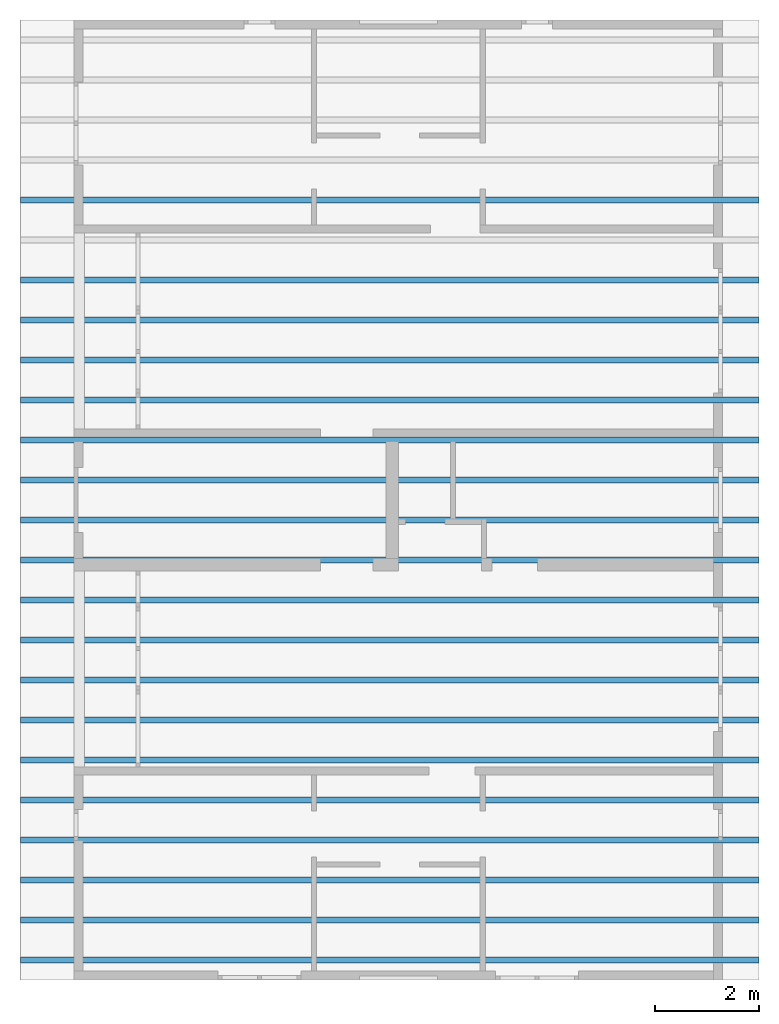
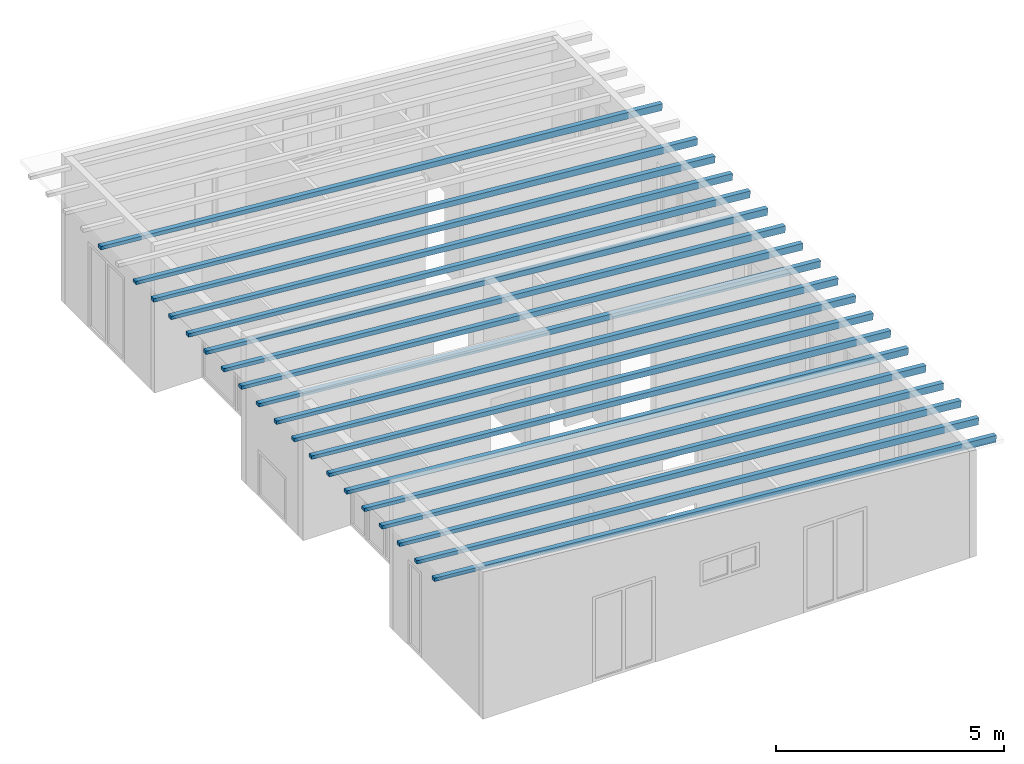
# One storey, part 3 of 13: 19 beams.
"""IFC2X3 building model written with IfcOpenShell, lengths in millimetres."""

import ifcopenshell
import ifcopenshell.guid

model = None  # the IFC model being written
_history = None  # IfcOwnerHistory: only IFC2X3 demands one
_inside = {}  # id of a spatial element -> (the spatial element, [elements in it])
_under = {}  # id of a project, library or spatial element -> (it, [spatial elements below it])
_declared = {}  # id of a project -> (the project, [libraries it declares])
_typed = {}  # id of a type object -> (the type object, [elements of that type])
_made_of = {}  # id of a material, layer set ... -> (it, [elements and type objects made of it])


def new_model(schema):
    """Start an empty IFC model of exactly this schema.

    Asked for "IFC4X3", IfcOpenShell would pick the latest addendum, in which some entities
    have other attributes; the version numbers below select the first issue.
    IFC2X3 requires an IfcOwnerHistory on every rooted entity: one is made here for all.
    """
    global model, _history
    if schema == "IFC4X3":
        model = ifcopenshell.file(schema_version=(4, 3, 0, 0))
    else:
        model = ifcopenshell.file(schema=schema)
    _inside.clear()
    _under.clear()
    _declared.clear()
    _typed.clear()
    _made_of.clear()
    _history = None
    if model.schema == "IFC2X3":
        org = make("IfcOrganization", Name="unknown")
        user = make(
            "IfcPersonAndOrganization",
            ThePerson=make("IfcPerson", FamilyName="unknown"),
            TheOrganization=org,
        )
        app = make(
            "IfcApplication",
            ApplicationDeveloper=org,
            Version="unknown",
            ApplicationFullName="unknown",
            ApplicationIdentifier="unknown",
        )
        _history = make(
            "IfcOwnerHistory",
            OwningUser=user,
            OwningApplication=app,
            ChangeAction="ADDED",
            CreationDate=0,
        )
    return model


def make(cls, **values):
    """One entity of the class cls with the attributes given. An attribute that is None is left unset."""
    return model.create_entity(
        cls, **{name: value for name, value in values.items() if value is not None}
    )


def entity(cls, *values):
    """Any entity or typed value of the class cls, its attributes in the order of the schema. None: left unset."""
    e = model.create_entity(cls)
    for i, value in enumerate(values):
        if value is not None:
            e[i] = value
    return e


def rooted(cls, **values):
    """An entity with a GlobalId (a new one), such as an element, a storey or a relation."""
    return make(cls, GlobalId=ifcopenshell.guid.new(), OwnerHistory=_history, **values)


def si_unit(unit_type, name, prefix=None):
    """IfcSIUnit, for example si_unit("LENGTHUNIT", "METRE", prefix="MILLI")."""
    return make("IfcSIUnit", UnitType=unit_type, Prefix=prefix, Name=name)


def converted_unit(unit_type, name, factor, base, dimensions=None, offset=None):
    """IfcConversionBasedUnit, such as the inch: factor (a typed value) times the base unit."""
    return make(
        "IfcConversionBasedUnit"
        if offset is None
        else "IfcConversionBasedUnitWithOffset",
        ConversionOffset=offset,
        Dimensions=None
        if dimensions is None
        else entity("IfcDimensionalExponents", *dimensions),
        UnitType=unit_type,
        Name=name,
        ConversionFactor=make(
            "IfcMeasureWithUnit", ValueComponent=factor, UnitComponent=base
        ),
    )


def assignment(units):
    """IfcUnitAssignment: the units of a project."""
    return None if units is None else make("IfcUnitAssignment", Units=units)


def point(xyz):
    """IfcCartesianPoint."""
    return None if xyz is None else make("IfcCartesianPoint", Coordinates=xyz)


def direction(xyz):
    """IfcDirection."""
    return None if xyz is None else make("IfcDirection", DirectionRatios=xyz)


def frame(location, z_axis=None, x_axis=None):
    """IfcAxis2Placement3D, a coordinate frame: its origin and axes. An axis left out is left unset."""
    return make(
        "IfcAxis2Placement3D",
        Location=point(location),
        Axis=direction(z_axis),
        RefDirection=direction(x_axis),
    )


def origin():
    """The frame at (0, 0, 0) with its axes left unset."""
    return frame((0.0, 0.0, 0.0))


def place(relative_to, where):
    """IfcLocalPlacement: puts the frame where relative to a parent placement (None: the world)."""
    return make(
        "IfcLocalPlacement", PlacementRelTo=relative_to, RelativePlacement=where
    )


def context(
    kind, dimensions, precision=None, world=None, true_north=None, identifier=None
):
    """IfcGeometricRepresentationContext, for example the 3D "Model" context."""
    return make(
        "IfcGeometricRepresentationContext",
        ContextIdentifier=identifier,
        ContextType=kind,
        CoordinateSpaceDimension=dimensions,
        Precision=precision,
        WorldCoordinateSystem=world,
        TrueNorth=true_north,
    )


def project(units=None, contexts=None):
    """IfcProject with its units and contexts."""
    return rooted(
        "IfcProject",
        Name="project",
        RepresentationContexts=contexts,
        UnitsInContext=assignment(units),
    )


def spatial(cls, under=None, at=None, **own):
    """A site, building, storey or space (cls), placed at a placement, below another one or the project."""
    s = rooted(cls, ObjectPlacement=at, **own)
    if under is not None:
        _under.setdefault(under.id(), (under, []))[1].append(s)
    return s


def faces_of(points, faces, orient=None, outer=None):
    """IfcFace entities. A face is a list of loops; a loop is a list of indices into points, from 0.

    orient and outer hold one flag for each loop. By default every Orientation is true, the
    first loop of a face is its IfcFaceOuterBound and the others are IfcFaceBound.
    """
    made = []
    for i, loops in enumerate(faces):
        bounds = []
        for j, loop in enumerate(loops):
            is_outer = j == 0 if outer is None else outer[i][j]
            bounds.append(
                make(
                    "IfcFaceOuterBound" if is_outer else "IfcFaceBound",
                    Bound=make("IfcPolyLoop", Polygon=[points[k] for k in loop]),
                    Orientation=True if orient is None else orient[i][j],
                )
            )
        made.append(make("IfcFace", Bounds=bounds))
    return made


def faceted_brep(points, faces, orient=None, outer=None, voids=None):
    """IfcFacetedBrep: a solid bounded by flat faces; with voids (closed shells), ...WithVoids."""
    shared = [point(p) for p in points]
    hull = make("IfcClosedShell", CfsFaces=faces_of(shared, faces, orient, outer))
    if voids is None:
        return make("IfcFacetedBrep", Outer=hull)
    return make(
        "IfcFacetedBrepWithVoids",
        Outer=hull,
        Voids=[
            make(cls, CfsFaces=faces_of(shared, fs, o, b)) for cls, fs, o, b in voids
        ],
    )


def shape(context_of_items, identifier, shape_type, items):
    """IfcShapeRepresentation: the items that make up one representation, for example the "Body"."""
    return make(
        "IfcShapeRepresentation",
        ContextOfItems=context_of_items,
        RepresentationIdentifier=identifier,
        RepresentationType=shape_type,
        Items=items,
    )


def made_of(thing, what):
    """Note that an element or type object is made of a material, layer set ...; save() writes the relation."""
    if what is not None:
        _made_of.setdefault(what.id(), (what, []))[1].append(thing)
    return thing


def element(
    cls,
    number,
    at=None,
    inside=None,
    cuts=None,
    type_object=None,
    material=None,
    context=None,
    identifier="Body",
    shape_type=None,
    held_by="IfcProductDefinitionShape",
    body=None,
    shapes=None,
    **own,
):
    """One element of the class cls, such as IfcWall. Its Tag is "e" and its number.

    at: its placement. inside: the storey or other place that contains it. cuts: it is an
    opening in that element (IfcRelVoidsElement). A single representation is given by context,
    identifier, shape_type and body (its items); several are given by shapes. held_by: the class
    of the entity that holds the representations. save() writes the other relations.
    """
    e = rooted(cls, Tag="e%d" % number, ObjectPlacement=at, **own)
    if body is not None:
        shapes = [shape(context, identifier, shape_type, body)]
    if shapes is not None:
        e.Representation = make(held_by, Representations=shapes)
    if inside is not None:
        _inside.setdefault(inside.id(), (inside, []))[1].append(e)
    if cuts is not None:
        rooted(
            "IfcRelVoidsElement", RelatingBuildingElement=cuts, RelatedOpeningElement=e
        )
    if type_object is not None:
        _typed.setdefault(type_object.id(), (type_object, []))[1].append(e)
    return made_of(e, material)


def aggregate(whole, parts):
    """IfcRelAggregates: a whole, such as a stair, and the parts it consists of."""
    return rooted("IfcRelAggregates", RelatingObject=whole, RelatedObjects=parts)


def save(model, path):
    """Write the relations noted so far, then the file.

    IfcRelAggregates (storeys below a building ...), IfcRelContainedInSpatialStructure (elements
    in a storey), IfcRelDefinesByType, IfcRelAssociatesMaterial and IfcRelDeclares: one each for
    every whole, place, type object, material and project.
    """
    for whole, parts in _under.values():
        aggregate(whole, parts)
    for where, things in _inside.values():
        rooted(
            "IfcRelContainedInSpatialStructure",
            RelatedElements=things,
            RelatingStructure=where,
        )
    for kind, things in _typed.values():
        rooted("IfcRelDefinesByType", RelatedObjects=things, RelatingType=kind)
    for what, things in _made_of.values():
        rooted("IfcRelAssociatesMaterial", RelatedObjects=things, RelatingMaterial=what)
    for by, libraries in _declared.values():
        rooted("IfcRelDeclares", RelatingContext=by, RelatedDefinitions=libraries)
    model.write(path)


model = new_model("IFC2X3")

# Units and contexts
model_context = context("Model", 3, precision=1e-05, world=origin())
plan_context = context("Plan", 3, precision=1e-05, world=origin())
ifc_project = project(units=[si_unit("LENGTHUNIT", "METRE", prefix="MILLI"), converted_unit("PLANEANGLEUNIT", "DEGREE", entity("IfcPlaneAngleMeasure", 0.0174532925199433), si_unit("PLANEANGLEUNIT", "RADIAN"), dimensions=[0, 0, 0, 0, 0, 0, 0]), si_unit("AREAUNIT", "SQUARE_METRE"), si_unit("VOLUMEUNIT", "CUBIC_METRE")], contexts=[model_context, plan_context])

# Building, storey
building_placement = place(None, origin())
building = spatial("IfcBuilding", under=ifc_project, at=building_placement, CompositionType="ELEMENT")
storey_placement = place(building_placement, frame((0.0, 0.0, 4770.0), z_axis=(0.0, 0.0, 1.0), x_axis=(1.0, 0.0, 0.0)))
storey = spatial("IfcBuildingStorey", under=building, at=storey_placement, Name="Geschoss", CompositionType="ELEMENT", Elevation=4770.0)

# Beams
beam_1_placement = place(storey_placement, frame((0.0, 0.0, -4770.0)))
element("IfcBeam", 1, at=beam_1_placement, inside=storey, context=model_context, shape_type="Brep", body=[
    faceted_brep([(34385.6880708781, 6279.68749999659, 7555.99098007664), (20155.7175901036, 6279.68750006627, 8710.60829407405), (20155.7175901036, 6399.68750006627, 8710.60829407405), (34385.6880708781, 6399.68749999659, 7555.99098007664), (34370.0000371835, 6279.68749999666, 7376.67593442012), (34370.0000371835, 6399.68749999666, 7376.67593442012), (20155.7175901036, 6399.68750006626, 8620.26450869515), (20155.7175901036, 6279.68750006626, 8620.26450869515), (34370.0000371835, 6279.68749999666, 7376.67593442012), (20155.7175901036, 6279.68750006626, 8620.26450869515), (20155.7175901036, 6279.68750006627, 8710.60829407405), (34385.6880708781, 6279.68749999659, 7555.99098007664), (20155.7175901036, 6279.68750006626, 8620.26450869515), (20155.7175901036, 6399.68750006626, 8620.26450869515), (20155.7175901036, 6399.68750006627, 8710.60829407405), (20155.7175901036, 6279.68750006627, 8710.60829407405), (20155.7175901036, 6399.68750006626, 8620.26450869515), (34370.0000371835, 6399.68749999666, 7376.67593442012), (34385.6880708781, 6399.68749999659, 7555.99098007664), (20155.7175901036, 6399.68750006627, 8710.60829407405), (34370.0000371835, 6399.68749999666, 7376.67593442012), (34370.0000371835, 6279.68749999666, 7376.67593442012), (34385.6880708781, 6279.68749999659, 7555.99098007664), (34385.6880708781, 6399.68749999659, 7555.99098007664)], [[[0, 1, 2, 3]], [[4, 5, 6, 7]], [[8, 9, 10, 11]], [[12, 13, 14, 15]], [[16, 17, 18, 19]], [[20, 21, 22, 23]]], orient=[[False], [False], [False], [False], [False], [False]]),
])
beam_2_placement = place(storey_placement, frame((0.0, 0.0, -4770.0)))
element("IfcBeam", 2, at=beam_2_placement, inside=storey, context=model_context, shape_type="Brep", body=[
    faceted_brep([(34385.6880708781, 4738.02083332992, 7555.99098007664), (20155.7175901036, 4738.0208333996, 8710.60829407405), (20155.7175901036, 4858.0208333996, 8710.60829407405), (34385.6880708781, 4858.02083332992, 7555.99098007664), (34370.0000371835, 4738.02083333, 7376.67593442012), (34370.0000371835, 4858.02083333, 7376.67593442012), (20155.7175901036, 4858.0208333996, 8620.26450869515), (20155.7175901036, 4738.0208333996, 8620.26450869515), (34370.0000371835, 4738.02083333, 7376.67593442012), (20155.7175901036, 4738.0208333996, 8620.26450869515), (20155.7175901036, 4738.0208333996, 8710.60829407405), (34385.6880708781, 4738.02083332992, 7555.99098007664), (20155.7175901036, 4738.0208333996, 8620.26450869515), (20155.7175901036, 4858.0208333996, 8620.26450869515), (20155.7175901036, 4858.0208333996, 8710.60829407405), (20155.7175901036, 4738.0208333996, 8710.60829407405), (20155.7175901036, 4858.0208333996, 8620.26450869515), (34370.0000371835, 4858.02083333, 7376.67593442012), (34385.6880708781, 4858.02083332992, 7555.99098007664), (20155.7175901036, 4858.0208333996, 8710.60829407405), (34370.0000371835, 4858.02083333, 7376.67593442012), (34370.0000371835, 4738.02083333, 7376.67593442012), (34385.6880708781, 4738.02083332992, 7555.99098007664), (34385.6880708781, 4858.02083332992, 7555.99098007664)], [[[0, 1, 2, 3]], [[4, 5, 6, 7]], [[8, 9, 10, 11]], [[12, 13, 14, 15]], [[16, 17, 18, 19]], [[20, 21, 22, 23]]], orient=[[False], [False], [False], [False], [False], [False]]),
])
beam_3_placement = place(storey_placement, frame((0.0, 0.0, -4770.0)))
element("IfcBeam", 3, at=beam_3_placement, inside=storey, context=model_context, shape_type="Brep", body=[
    faceted_brep([(34385.6880708781, 3967.18749999659, 7555.99098007664), (20155.7175901036, 3967.18750006627, 8710.60829407405), (20155.7175901036, 4087.18750006627, 8710.60829407405), (34385.6880708781, 4087.18749999659, 7555.99098007664), (34370.0000371835, 3967.18749999666, 7376.67593442012), (34370.0000371835, 4087.18749999666, 7376.67593442012), (20155.7175901036, 4087.18750006627, 8620.26450869515), (20155.7175901036, 3967.18750006627, 8620.26450869515), (34370.0000371835, 3967.18749999666, 7376.67593442012), (20155.7175901036, 3967.18750006627, 8620.26450869515), (20155.7175901036, 3967.18750006627, 8710.60829407405), (34385.6880708781, 3967.18749999659, 7555.99098007664), (20155.7175901036, 3967.18750006627, 8620.26450869515), (20155.7175901036, 4087.18750006627, 8620.26450869515), (20155.7175901036, 4087.18750006627, 8710.60829407405), (20155.7175901036, 3967.18750006627, 8710.60829407405), (20155.7175901036, 4087.18750006627, 8620.26450869515), (34370.0000371835, 4087.18749999666, 7376.67593442012), (34385.6880708781, 4087.18749999659, 7555.99098007664), (20155.7175901036, 4087.18750006627, 8710.60829407405), (34370.0000371835, 4087.18749999666, 7376.67593442012), (34370.0000371835, 3967.18749999666, 7376.67593442012), (34385.6880708781, 3967.18749999659, 7555.99098007664), (34385.6880708781, 4087.18749999659, 7555.99098007664)], [[[0, 1, 2, 3]], [[4, 5, 6, 7]], [[8, 9, 10, 11]], [[12, 13, 14, 15]], [[16, 17, 18, 19]], [[20, 21, 22, 23]]], orient=[[False], [False], [False], [False], [False], [False]]),
])
beam_4_placement = place(storey_placement, frame((0.0, 0.0, -4770.0)))
element("IfcBeam", 4, at=beam_4_placement, inside=storey, context=model_context, shape_type="Brep", body=[
    faceted_brep([(34385.6880708781, 3196.35416666325, 7555.99098007664), (20155.7175901036, 3196.35416673293, 8710.60829407405), (20155.7175901036, 3316.35416673293, 8710.60829407405), (34385.6880708781, 3316.35416666325, 7555.99098007664), (34370.0000371835, 3196.35416666333, 7376.67593442012), (34370.0000371835, 3316.35416666333, 7376.67593442012), (20155.7175901036, 3316.35416673293, 8620.26450869515), (20155.7175901036, 3196.35416673293, 8620.26450869515), (34370.0000371835, 3196.35416666333, 7376.67593442012), (20155.7175901036, 3196.35416673293, 8620.26450869515), (20155.7175901036, 3196.35416673293, 8710.60829407405), (34385.6880708781, 3196.35416666325, 7555.99098007664), (20155.7175901036, 3196.35416673293, 8620.26450869515), (20155.7175901036, 3316.35416673293, 8620.26450869515), (20155.7175901036, 3316.35416673293, 8710.60829407405), (20155.7175901036, 3196.35416673293, 8710.60829407405), (20155.7175901036, 3316.35416673293, 8620.26450869515), (34370.0000371835, 3316.35416666333, 7376.67593442012), (34385.6880708781, 3316.35416666325, 7555.99098007664), (20155.7175901036, 3316.35416673293, 8710.60829407405), (34370.0000371835, 3316.35416666333, 7376.67593442012), (34370.0000371835, 3196.35416666333, 7376.67593442012), (34385.6880708781, 3196.35416666325, 7555.99098007664), (34385.6880708781, 3316.35416666325, 7555.99098007664)], [[[0, 1, 2, 3]], [[4, 5, 6, 7]], [[8, 9, 10, 11]], [[12, 13, 14, 15]], [[16, 17, 18, 19]], [[20, 21, 22, 23]]], orient=[[False], [False], [False], [False], [False], [False]]),
])
beam_5_placement = place(storey_placement, frame((0.0, 0.0, -4770.0)))
element("IfcBeam", 5, at=beam_5_placement, inside=storey, context=model_context, shape_type="Brep", body=[
    faceted_brep([(34385.6880708781, 2425.52083332992, 7555.99098007664), (20155.7175901036, 2425.5208333996, 8710.60829407405), (20155.7175901036, 2545.5208333996, 8710.60829407405), (34385.6880708781, 2545.52083332992, 7555.99098007664), (34370.0000371835, 2425.52083333, 7376.67593442012), (34370.0000371835, 2545.52083333, 7376.67593442012), (20155.7175901036, 2545.5208333996, 8620.26450869515), (20155.7175901036, 2425.5208333996, 8620.26450869515), (34370.0000371835, 2425.52083333, 7376.67593442012), (20155.7175901036, 2425.5208333996, 8620.26450869515), (20155.7175901036, 2425.5208333996, 8710.60829407405), (34385.6880708781, 2425.52083332992, 7555.99098007664), (20155.7175901036, 2425.5208333996, 8620.26450869515), (20155.7175901036, 2545.5208333996, 8620.26450869515), (20155.7175901036, 2545.5208333996, 8710.60829407405), (20155.7175901036, 2425.5208333996, 8710.60829407405), (20155.7175901036, 2545.5208333996, 8620.26450869515), (34370.0000371835, 2545.52083333, 7376.67593442012), (34385.6880708781, 2545.52083332992, 7555.99098007664), (20155.7175901036, 2545.5208333996, 8710.60829407405), (34370.0000371835, 2545.52083333, 7376.67593442012), (34370.0000371835, 2425.52083333, 7376.67593442012), (34385.6880708781, 2425.52083332992, 7555.99098007664), (34385.6880708781, 2545.52083332992, 7555.99098007664)], [[[0, 1, 2, 3]], [[4, 5, 6, 7]], [[8, 9, 10, 11]], [[12, 13, 14, 15]], [[16, 17, 18, 19]], [[20, 21, 22, 23]]], orient=[[False], [False], [False], [False], [False], [False]]),
])
beam_6_placement = place(storey_placement, frame((0.0, 0.0, -4770.0)))
element("IfcBeam", 6, at=beam_6_placement, inside=storey, context=model_context, shape_type="Brep", body=[
    faceted_brep([(34385.6880708781, 1654.68749999659, 7555.99098007664), (20155.7175901036, 1654.68750006627, 8710.60829407405), (20155.7175901036, 1774.68750006627, 8710.60829407405), (34385.6880708781, 1774.68749999659, 7555.99098007664), (34370.0000371835, 1654.68749999666, 7376.67593442012), (34370.0000371835, 1774.68749999666, 7376.67593442012), (20155.7175901036, 1774.68750006627, 8620.26450869515), (20155.7175901036, 1654.68750006627, 8620.26450869515), (34370.0000371835, 1654.68749999666, 7376.67593442012), (20155.7175901036, 1654.68750006627, 8620.26450869515), (20155.7175901036, 1654.68750006627, 8710.60829407405), (34385.6880708781, 1654.68749999659, 7555.99098007664), (20155.7175901036, 1654.68750006627, 8620.26450869515), (20155.7175901036, 1774.68750006627, 8620.26450869515), (20155.7175901036, 1774.68750006627, 8710.60829407405), (20155.7175901036, 1654.68750006627, 8710.60829407405), (20155.7175901036, 1774.68750006627, 8620.26450869515), (34370.0000371835, 1774.68749999666, 7376.67593442012), (34385.6880708781, 1774.68749999659, 7555.99098007664), (20155.7175901036, 1774.68750006627, 8710.60829407405), (34370.0000371835, 1774.68749999666, 7376.67593442012), (34370.0000371835, 1654.68749999666, 7376.67593442012), (34385.6880708781, 1654.68749999659, 7555.99098007664), (34385.6880708781, 1774.68749999659, 7555.99098007664)], [[[0, 1, 2, 3]], [[4, 5, 6, 7]], [[8, 9, 10, 11]], [[12, 13, 14, 15]], [[16, 17, 18, 19]], [[20, 21, 22, 23]]], orient=[[False], [False], [False], [False], [False], [False]]),
])
beam_7_placement = place(storey_placement, frame((0.0, 0.0, -4770.0)))
element("IfcBeam", 7, at=beam_7_placement, inside=storey, context=model_context, shape_type="Brep", body=[
    faceted_brep([(34385.6880708781, 883.854166663251, 7555.99098007664), (20155.7175901036, 883.85416673293, 8710.60829407405), (20155.7175901036, 1003.85416673293, 8710.60829407405), (34385.6880708781, 1003.85416666325, 7555.99098007664), (34370.0000371835, 883.854166663328, 7376.67593442012), (34370.0000371835, 1003.85416666333, 7376.67593442012), (20155.7175901036, 1003.85416673293, 8620.26450869515), (20155.7175901036, 883.85416673293, 8620.26450869515), (34370.0000371835, 883.854166663328, 7376.67593442012), (20155.7175901036, 883.85416673293, 8620.26450869515), (20155.7175901036, 883.85416673293, 8710.60829407405), (34385.6880708781, 883.854166663251, 7555.99098007664), (20155.7175901036, 883.85416673293, 8620.26450869515), (20155.7175901036, 1003.85416673293, 8620.26450869515), (20155.7175901036, 1003.85416673293, 8710.60829407405), (20155.7175901036, 883.85416673293, 8710.60829407405), (20155.7175901036, 1003.85416673293, 8620.26450869515), (34370.0000371835, 1003.85416666333, 7376.67593442012), (34385.6880708781, 1003.85416666325, 7555.99098007664), (20155.7175901036, 1003.85416673293, 8710.60829407405), (34370.0000371835, 1003.85416666333, 7376.67593442012), (34370.0000371835, 883.854166663328, 7376.67593442012), (34385.6880708781, 883.854166663251, 7555.99098007664), (34385.6880708781, 1003.85416666325, 7555.99098007664)], [[[0, 1, 2, 3]], [[4, 5, 6, 7]], [[8, 9, 10, 11]], [[12, 13, 14, 15]], [[16, 17, 18, 19]], [[20, 21, 22, 23]]], orient=[[False], [False], [False], [False], [False], [False]]),
])
beam_8_placement = place(storey_placement, frame((0.0, 0.0, -4770.0)))
element("IfcBeam", 8, at=beam_8_placement, inside=storey, context=model_context, shape_type="Brep", body=[
    faceted_brep([(34385.6880708781, 113.020833329919, 7555.99098007664), (20155.7175901036, 113.020833399599, 8710.60829407405), (20155.7175901036, 233.020833399599, 8710.60829407405), (34385.6880708781, 233.020833329919, 7555.99098007664), (34370.0000371835, 113.020833329996, 7376.67593442012), (34370.0000371835, 233.020833329996, 7376.67593442012), (20155.7175901036, 233.020833399599, 8620.26450869515), (20155.7175901036, 113.020833399598, 8620.26450869515), (34370.0000371835, 113.020833329996, 7376.67593442012), (20155.7175901036, 113.020833399598, 8620.26450869515), (20155.7175901036, 113.020833399599, 8710.60829407405), (34385.6880708781, 113.020833329919, 7555.99098007664), (20155.7175901036, 113.020833399598, 8620.26450869515), (20155.7175901036, 233.020833399599, 8620.26450869515), (20155.7175901036, 233.020833399599, 8710.60829407405), (20155.7175901036, 113.020833399599, 8710.60829407405), (20155.7175901036, 233.020833399599, 8620.26450869515), (34370.0000371835, 233.020833329996, 7376.67593442012), (34385.6880708781, 233.020833329919, 7555.99098007664), (20155.7175901036, 233.020833399599, 8710.60829407405), (34370.0000371835, 233.020833329996, 7376.67593442012), (34370.0000371835, 113.020833329996, 7376.67593442012), (34385.6880708781, 113.020833329919, 7555.99098007664), (34385.6880708781, 233.020833329919, 7555.99098007664)], [[[0, 1, 2, 3]], [[4, 5, 6, 7]], [[8, 9, 10, 11]], [[12, 13, 14, 15]], [[16, 17, 18, 19]], [[20, 21, 22, 23]]], orient=[[False], [False], [False], [False], [False], [False]]),
])
beam_9_placement = place(storey_placement, frame((0.0, 0.0, -4770.0)))
element("IfcBeam", 9, at=beam_9_placement, inside=storey, context=model_context, shape_type="Brep", body=[
    faceted_brep([(34385.6880708781, -657.812500003415, 7555.99098007664), (20155.7175901036, -657.812499933736, 8710.60829407405), (20155.7175901036, -537.812499933736, 8710.60829407405), (34385.6880708781, -537.812500003415, 7555.99098007664), (34370.0000371835, -657.812500003338, 7376.67593442012), (34370.0000371835, -537.812500003338, 7376.67593442012), (20155.7175901036, -537.812499933736, 8620.26450869515), (20155.7175901036, -657.812499933736, 8620.26450869515), (34370.0000371835, -657.812500003338, 7376.67593442012), (20155.7175901036, -657.812499933736, 8620.26450869515), (20155.7175901036, -657.812499933736, 8710.60829407405), (34385.6880708781, -657.812500003415, 7555.99098007664), (20155.7175901036, -657.812499933736, 8620.26450869515), (20155.7175901036, -537.812499933736, 8620.26450869515), (20155.7175901036, -537.812499933736, 8710.60829407405), (20155.7175901036, -657.812499933736, 8710.60829407405), (20155.7175901036, -537.812499933736, 8620.26450869515), (34370.0000371835, -537.812500003338, 7376.67593442012), (34385.6880708781, -537.812500003415, 7555.99098007664), (20155.7175901036, -537.812499933736, 8710.60829407405), (34370.0000371835, -537.812500003338, 7376.67593442012), (34370.0000371835, -657.812500003338, 7376.67593442012), (34385.6880708781, -657.812500003415, 7555.99098007664), (34385.6880708781, -537.812500003415, 7555.99098007664)], [[[0, 1, 2, 3]], [[4, 5, 6, 7]], [[8, 9, 10, 11]], [[12, 13, 14, 15]], [[16, 17, 18, 19]], [[20, 21, 22, 23]]], orient=[[False], [False], [False], [False], [False], [False]]),
])
beam_10_placement = place(storey_placement, frame((0.0, 0.0, -4770.0)))
element("IfcBeam", 10, at=beam_10_placement, inside=storey, context=model_context, shape_type="Brep", body=[
    faceted_brep([(34385.6880708781, -1428.64583333675, 7555.99098007664), (20155.7175901036, -1428.64583326707, 8710.60829407405), (20155.7175901036, -1308.64583326707, 8710.60829407405), (34385.6880708781, -1308.64583333675, 7555.99098007664), (34370.0000371835, -1428.64583333667, 7376.67593442012), (34370.0000371835, -1308.64583333667, 7376.67593442012), (20155.7175901036, -1308.64583326707, 8620.26450869515), (20155.7175901036, -1428.64583326707, 8620.26450869515), (34370.0000371835, -1428.64583333667, 7376.67593442012), (20155.7175901036, -1428.64583326707, 8620.26450869515), (20155.7175901036, -1428.64583326707, 8710.60829407405), (34385.6880708781, -1428.64583333675, 7555.99098007664), (20155.7175901036, -1428.64583326707, 8620.26450869515), (20155.7175901036, -1308.64583326707, 8620.26450869515), (20155.7175901036, -1308.64583326707, 8710.60829407405), (20155.7175901036, -1428.64583326707, 8710.60829407405), (20155.7175901036, -1308.64583326707, 8620.26450869515), (34370.0000371835, -1308.64583333667, 7376.67593442012), (34385.6880708781, -1308.64583333675, 7555.99098007664), (20155.7175901036, -1308.64583326707, 8710.60829407405), (34370.0000371835, -1308.64583333667, 7376.67593442012), (34370.0000371835, -1428.64583333667, 7376.67593442012), (34385.6880708781, -1428.64583333675, 7555.99098007664), (34385.6880708781, -1308.64583333675, 7555.99098007664)], [[[0, 1, 2, 3]], [[4, 5, 6, 7]], [[8, 9, 10, 11]], [[12, 13, 14, 15]], [[16, 17, 18, 19]], [[20, 21, 22, 23]]], orient=[[False], [False], [False], [False], [False], [False]]),
])
beam_11_placement = place(storey_placement, frame((0.0, 0.0, -4770.0)))
element("IfcBeam", 11, at=beam_11_placement, inside=storey, context=model_context, shape_type="Brep", body=[
    faceted_brep([(34385.6880708781, -2199.47916667008, 7555.99098007664), (20155.7175901036, -2199.4791666004, 8710.60829407405), (20155.7175901036, -2079.4791666004, 8710.60829407405), (34385.6880708781, -2079.47916667008, 7555.99098007664), (34370.0000371835, -2199.47916667, 7376.67593442012), (34370.0000371835, -2079.47916667, 7376.67593442012), (20155.7175901036, -2079.4791666004, 8620.26450869515), (20155.7175901036, -2199.4791666004, 8620.26450869515), (34370.0000371835, -2199.47916667, 7376.67593442012), (20155.7175901036, -2199.4791666004, 8620.26450869515), (20155.7175901036, -2199.4791666004, 8710.60829407405), (34385.6880708781, -2199.47916667008, 7555.99098007664), (20155.7175901036, -2199.4791666004, 8620.26450869515), (20155.7175901036, -2079.4791666004, 8620.26450869515), (20155.7175901036, -2079.4791666004, 8710.60829407405), (20155.7175901036, -2199.4791666004, 8710.60829407405), (20155.7175901036, -2079.4791666004, 8620.26450869515), (34370.0000371835, -2079.47916667, 7376.67593442012), (34385.6880708781, -2079.47916667008, 7555.99098007664), (20155.7175901036, -2079.4791666004, 8710.60829407405), (34370.0000371835, -2079.47916667, 7376.67593442012), (34370.0000371835, -2199.47916667, 7376.67593442012), (34385.6880708781, -2199.47916667008, 7555.99098007664), (34385.6880708781, -2079.47916667008, 7555.99098007664)], [[[0, 1, 2, 3]], [[4, 5, 6, 7]], [[8, 9, 10, 11]], [[12, 13, 14, 15]], [[16, 17, 18, 19]], [[20, 21, 22, 23]]], orient=[[False], [False], [False], [False], [False], [False]]),
])
beam_12_placement = place(storey_placement, frame((0.0, 0.0, -4770.0)))
element("IfcBeam", 12, at=beam_12_placement, inside=storey, context=model_context, shape_type="Brep", body=[
    faceted_brep([(34385.6880708781, -2970.31250000341, 7555.99098007664), (20155.7175901036, -2970.31249993373, 8710.60829407405), (20155.7175901036, -2850.31249993373, 8710.60829407405), (34385.6880708781, -2850.31250000341, 7555.99098007664), (34370.0000371835, -2970.31250000334, 7376.67593442012), (34370.0000371835, -2850.31250000334, 7376.67593442012), (20155.7175901036, -2850.31249993373, 8620.26450869515), (20155.7175901036, -2970.31249993373, 8620.26450869515), (34370.0000371835, -2970.31250000334, 7376.67593442012), (20155.7175901036, -2970.31249993373, 8620.26450869515), (20155.7175901036, -2970.31249993373, 8710.60829407405), (34385.6880708781, -2970.31250000341, 7555.99098007664), (20155.7175901036, -2970.31249993373, 8620.26450869515), (20155.7175901036, -2850.31249993373, 8620.26450869515), (20155.7175901036, -2850.31249993373, 8710.60829407405), (20155.7175901036, -2970.31249993373, 8710.60829407405), (20155.7175901036, -2850.31249993373, 8620.26450869515), (34370.0000371835, -2850.31250000334, 7376.67593442012), (34385.6880708781, -2850.31250000341, 7555.99098007664), (20155.7175901036, -2850.31249993373, 8710.60829407405), (34370.0000371835, -2850.31250000334, 7376.67593442012), (34370.0000371835, -2970.31250000334, 7376.67593442012), (34385.6880708781, -2970.31250000341, 7555.99098007664), (34385.6880708781, -2850.31250000341, 7555.99098007664)], [[[0, 1, 2, 3]], [[4, 5, 6, 7]], [[8, 9, 10, 11]], [[12, 13, 14, 15]], [[16, 17, 18, 19]], [[20, 21, 22, 23]]], orient=[[False], [False], [False], [False], [False], [False]]),
])
beam_13_placement = place(storey_placement, frame((0.0, 0.0, -4770.0)))
element("IfcBeam", 13, at=beam_13_placement, inside=storey, context=model_context, shape_type="Brep", body=[
    faceted_brep([(34385.6880708781, -3741.14583333675, 7555.99098007664), (20155.7175901036, -3741.14583326707, 8710.60829407405), (20155.7175901036, -3621.14583326707, 8710.60829407405), (34385.6880708781, -3621.14583333675, 7555.99098007664), (34370.0000371835, -3741.14583333667, 7376.67593442012), (34370.0000371835, -3621.14583333667, 7376.67593442012), (20155.7175901036, -3621.14583326707, 8620.26450869515), (20155.7175901036, -3741.14583326707, 8620.26450869515), (34370.0000371835, -3741.14583333667, 7376.67593442012), (20155.7175901036, -3741.14583326707, 8620.26450869515), (20155.7175901036, -3741.14583326707, 8710.60829407405), (34385.6880708781, -3741.14583333675, 7555.99098007664), (20155.7175901036, -3741.14583326707, 8620.26450869515), (20155.7175901036, -3621.14583326707, 8620.26450869515), (20155.7175901036, -3621.14583326707, 8710.60829407405), (20155.7175901036, -3741.14583326707, 8710.60829407405), (20155.7175901036, -3621.14583326707, 8620.26450869515), (34370.0000371835, -3621.14583333667, 7376.67593442012), (34385.6880708781, -3621.14583333675, 7555.99098007664), (20155.7175901036, -3621.14583326707, 8710.60829407405), (34370.0000371835, -3621.14583333667, 7376.67593442012), (34370.0000371835, -3741.14583333667, 7376.67593442012), (34385.6880708781, -3741.14583333675, 7555.99098007664), (34385.6880708781, -3621.14583333675, 7555.99098007664)], [[[0, 1, 2, 3]], [[4, 5, 6, 7]], [[8, 9, 10, 11]], [[12, 13, 14, 15]], [[16, 17, 18, 19]], [[20, 21, 22, 23]]], orient=[[False], [False], [False], [False], [False], [False]]),
])
beam_14_placement = place(storey_placement, frame((0.0, 0.0, -4770.0)))
element("IfcBeam", 14, at=beam_14_placement, inside=storey, context=model_context, shape_type="Brep", body=[
    faceted_brep([(34385.6880708781, -4511.97916667008, 7555.99098007664), (20155.7175901036, -4511.9791666004, 8710.60829407405), (20155.7175901036, -4391.9791666004, 8710.60829407405), (34385.6880708781, -4391.97916667008, 7555.99098007664), (34370.0000371835, -4511.97916667, 7376.67593442012), (34370.0000371835, -4391.97916667, 7376.67593442012), (20155.7175901036, -4391.9791666004, 8620.26450869515), (20155.7175901036, -4511.9791666004, 8620.26450869515), (34370.0000371835, -4511.97916667, 7376.67593442012), (20155.7175901036, -4511.9791666004, 8620.26450869515), (20155.7175901036, -4511.9791666004, 8710.60829407405), (34385.6880708781, -4511.97916667008, 7555.99098007664), (20155.7175901036, -4511.9791666004, 8620.26450869515), (20155.7175901036, -4391.9791666004, 8620.26450869515), (20155.7175901036, -4391.9791666004, 8710.60829407405), (20155.7175901036, -4511.9791666004, 8710.60829407405), (20155.7175901036, -4391.9791666004, 8620.26450869515), (34370.0000371835, -4391.97916667, 7376.67593442012), (34385.6880708781, -4391.97916667008, 7555.99098007664), (20155.7175901036, -4391.9791666004, 8710.60829407405), (34370.0000371835, -4391.97916667, 7376.67593442012), (34370.0000371835, -4511.97916667, 7376.67593442012), (34385.6880708781, -4511.97916667008, 7555.99098007664), (34385.6880708781, -4391.97916667008, 7555.99098007664)], [[[0, 1, 2, 3]], [[4, 5, 6, 7]], [[8, 9, 10, 11]], [[12, 13, 14, 15]], [[16, 17, 18, 19]], [[20, 21, 22, 23]]], orient=[[False], [False], [False], [False], [False], [False]]),
])
beam_15_placement = place(storey_placement, frame((0.0, 0.0, -4770.0)))
element("IfcBeam", 15, at=beam_15_placement, inside=storey, context=model_context, shape_type="Brep", body=[
    faceted_brep([(34385.6880708781, -5282.81250000341, 7555.99098007664), (20155.7175901036, -5282.81249993373, 8710.60829407405), (20155.7175901036, -5162.81249993373, 8710.60829407405), (34385.6880708781, -5162.81250000341, 7555.99098007664), (34370.0000371835, -5282.81250000334, 7376.67593442012), (34370.0000371835, -5162.81250000334, 7376.67593442012), (20155.7175901036, -5162.81249993374, 8620.26450869515), (20155.7175901036, -5282.81249993374, 8620.26450869515), (34370.0000371835, -5282.81250000334, 7376.67593442012), (20155.7175901036, -5282.81249993374, 8620.26450869515), (20155.7175901036, -5282.81249993373, 8710.60829407405), (34385.6880708781, -5282.81250000341, 7555.99098007664), (20155.7175901036, -5282.81249993374, 8620.26450869515), (20155.7175901036, -5162.81249993374, 8620.26450869515), (20155.7175901036, -5162.81249993373, 8710.60829407405), (20155.7175901036, -5282.81249993373, 8710.60829407405), (20155.7175901036, -5162.81249993374, 8620.26450869515), (34370.0000371835, -5162.81250000334, 7376.67593442012), (34385.6880708781, -5162.81250000341, 7555.99098007664), (20155.7175901036, -5162.81249993373, 8710.60829407405), (34370.0000371835, -5162.81250000334, 7376.67593442012), (34370.0000371835, -5282.81250000334, 7376.67593442012), (34385.6880708781, -5282.81250000341, 7555.99098007664), (34385.6880708781, -5162.81250000341, 7555.99098007664)], [[[0, 1, 2, 3]], [[4, 5, 6, 7]], [[8, 9, 10, 11]], [[12, 13, 14, 15]], [[16, 17, 18, 19]], [[20, 21, 22, 23]]], orient=[[False], [False], [False], [False], [False], [False]]),
])
beam_16_placement = place(storey_placement, frame((0.0, 0.0, -4770.0)))
element("IfcBeam", 16, at=beam_16_placement, inside=storey, context=model_context, shape_type="Brep", body=[
    faceted_brep([(34385.6880708781, -6053.64583333675, 7555.99098007664), (20155.7175901036, -6053.64583326707, 8710.60829407405), (20155.7175901036, -5933.64583326707, 8710.60829407405), (34385.6880708781, -5933.64583333675, 7555.99098007664), (34370.0000371835, -6053.64583333667, 7376.67593442012), (34370.0000371835, -5933.64583333667, 7376.67593442012), (20155.7175901036, -5933.64583326707, 8620.26450869515), (20155.7175901036, -6053.64583326707, 8620.26450869515), (34370.0000371835, -6053.64583333667, 7376.67593442012), (20155.7175901036, -6053.64583326707, 8620.26450869515), (20155.7175901036, -6053.64583326707, 8710.60829407405), (34385.6880708781, -6053.64583333675, 7555.99098007664), (20155.7175901036, -6053.64583326707, 8620.26450869515), (20155.7175901036, -5933.64583326707, 8620.26450869515), (20155.7175901036, -5933.64583326707, 8710.60829407405), (20155.7175901036, -6053.64583326707, 8710.60829407405), (20155.7175901036, -5933.64583326707, 8620.26450869515), (34370.0000371835, -5933.64583333667, 7376.67593442012), (34385.6880708781, -5933.64583333675, 7555.99098007664), (20155.7175901036, -5933.64583326707, 8710.60829407405), (34370.0000371835, -5933.64583333667, 7376.67593442012), (34370.0000371835, -6053.64583333667, 7376.67593442012), (34385.6880708781, -6053.64583333675, 7555.99098007664), (34385.6880708781, -5933.64583333675, 7555.99098007664)], [[[0, 1, 2, 3]], [[4, 5, 6, 7]], [[8, 9, 10, 11]], [[12, 13, 14, 15]], [[16, 17, 18, 19]], [[20, 21, 22, 23]]], orient=[[False], [False], [False], [False], [False], [False]]),
])
beam_17_placement = place(storey_placement, frame((0.0, 0.0, -4770.0)))
element("IfcBeam", 17, at=beam_17_placement, inside=storey, context=model_context, shape_type="Brep", body=[
    faceted_brep([(34385.6880708781, -6824.47916667008, 7555.99098007664), (20155.7175901036, -6824.4791666004, 8710.60829407405), (20155.7175901036, -6704.4791666004, 8710.60829407405), (34385.6880708781, -6704.47916667008, 7555.99098007664), (34370.0000371835, -6824.47916667, 7376.67593442012), (34370.0000371835, -6704.47916667, 7376.67593442012), (20155.7175901036, -6704.4791666004, 8620.26450869515), (20155.7175901036, -6824.4791666004, 8620.26450869515), (34370.0000371835, -6824.47916667, 7376.67593442012), (20155.7175901036, -6824.4791666004, 8620.26450869515), (20155.7175901036, -6824.4791666004, 8710.60829407405), (34385.6880708781, -6824.47916667008, 7555.99098007664), (20155.7175901036, -6824.4791666004, 8620.26450869515), (20155.7175901036, -6704.4791666004, 8620.26450869515), (20155.7175901036, -6704.4791666004, 8710.60829407405), (20155.7175901036, -6824.4791666004, 8710.60829407405), (20155.7175901036, -6704.4791666004, 8620.26450869515), (34370.0000371835, -6704.47916667, 7376.67593442012), (34385.6880708781, -6704.47916667008, 7555.99098007664), (20155.7175901036, -6704.4791666004, 8710.60829407405), (34370.0000371835, -6704.47916667, 7376.67593442012), (34370.0000371835, -6824.47916667, 7376.67593442012), (34385.6880708781, -6824.47916667008, 7555.99098007664), (34385.6880708781, -6704.47916667008, 7555.99098007664)], [[[0, 1, 2, 3]], [[4, 5, 6, 7]], [[8, 9, 10, 11]], [[12, 13, 14, 15]], [[16, 17, 18, 19]], [[20, 21, 22, 23]]], orient=[[False], [False], [False], [False], [False], [False]]),
])
beam_18_placement = place(storey_placement, frame((0.0, 0.0, -4770.0)))
element("IfcBeam", 18, at=beam_18_placement, inside=storey, context=model_context, shape_type="Brep", body=[
    faceted_brep([(34385.6880708781, -7595.31250000342, 7555.99098007664), (20155.7175901036, -7595.31249993374, 8710.60829407405), (20155.7175901036, -7475.31249993374, 8710.60829407405), (34385.6880708781, -7475.31250000342, 7555.99098007664), (34370.0000371835, -7595.31250000334, 7376.67593442012), (34370.0000371835, -7475.31250000334, 7376.67593442012), (20155.7175901036, -7475.31249993374, 8620.26450869515), (20155.7175901036, -7595.31249993374, 8620.26450869515), (34370.0000371835, -7595.31250000334, 7376.67593442012), (20155.7175901036, -7595.31249993374, 8620.26450869515), (20155.7175901036, -7595.31249993374, 8710.60829407405), (34385.6880708781, -7595.31250000342, 7555.99098007664), (20155.7175901036, -7595.31249993374, 8620.26450869515), (20155.7175901036, -7475.31249993374, 8620.26450869515), (20155.7175901036, -7475.31249993374, 8710.60829407405), (20155.7175901036, -7595.31249993374, 8710.60829407405), (20155.7175901036, -7475.31249993374, 8620.26450869515), (34370.0000371835, -7475.31250000334, 7376.67593442012), (34385.6880708781, -7475.31250000342, 7555.99098007664), (20155.7175901036, -7475.31249993374, 8710.60829407405), (34370.0000371835, -7475.31250000334, 7376.67593442012), (34370.0000371835, -7595.31250000334, 7376.67593442012), (34385.6880708781, -7595.31250000342, 7555.99098007664), (34385.6880708781, -7475.31250000342, 7555.99098007664)], [[[0, 1, 2, 3]], [[4, 5, 6, 7]], [[8, 9, 10, 11]], [[12, 13, 14, 15]], [[16, 17, 18, 19]], [[20, 21, 22, 23]]], orient=[[False], [False], [False], [False], [False], [False]]),
])
beam_19_placement = place(storey_placement, frame((0.0, 0.0, -4770.0)))
element("IfcBeam", 19, at=beam_19_placement, inside=storey, context=model_context, shape_type="Brep", body=[
    faceted_brep([(34385.6880708781, -8366.14583333675, 7555.99098007664), (20155.7175901036, -8366.14583326707, 8710.60829407405), (20155.7175901036, -8246.14583326707, 8710.60829407405), (34385.6880708781, -8246.14583333675, 7555.99098007664), (34370.0000371835, -8366.14583333667, 7376.67593442012), (34370.0000371835, -8246.14583333667, 7376.67593442012), (20155.7175901036, -8246.14583326707, 8620.26450869515), (20155.7175901036, -8366.14583326707, 8620.26450869515), (34370.0000371835, -8366.14583333667, 7376.67593442012), (20155.7175901036, -8366.14583326707, 8620.26450869515), (20155.7175901036, -8366.14583326707, 8710.60829407405), (34385.6880708781, -8366.14583333675, 7555.99098007664), (20155.7175901036, -8366.14583326707, 8620.26450869515), (20155.7175901036, -8246.14583326707, 8620.26450869515), (20155.7175901036, -8246.14583326707, 8710.60829407405), (20155.7175901036, -8366.14583326707, 8710.60829407405), (20155.7175901036, -8246.14583326707, 8620.26450869515), (34370.0000371835, -8246.14583333667, 7376.67593442012), (34385.6880708781, -8246.14583333675, 7555.99098007664), (20155.7175901036, -8246.14583326707, 8710.60829407405), (34370.0000371835, -8246.14583333667, 7376.67593442012), (34370.0000371835, -8366.14583333667, 7376.67593442012), (34385.6880708781, -8366.14583333675, 7555.99098007664), (34385.6880708781, -8246.14583333675, 7555.99098007664)], [[[0, 1, 2, 3]], [[4, 5, 6, 7]], [[8, 9, 10, 11]], [[12, 13, 14, 15]], [[16, 17, 18, 19]], [[20, 21, 22, 23]]], orient=[[False], [False], [False], [False], [False], [False]]),
])

save(model, "model.ifc")
